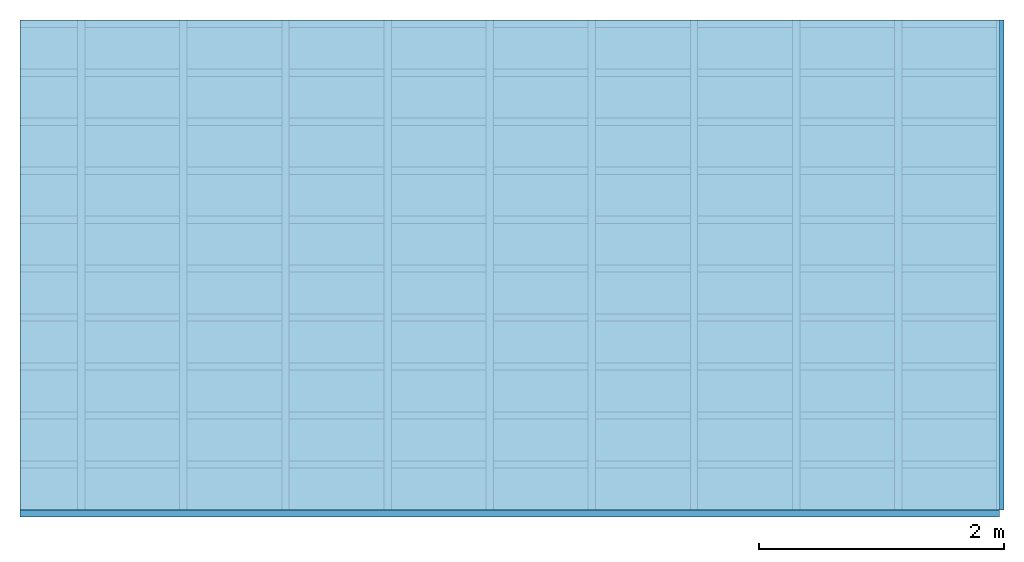
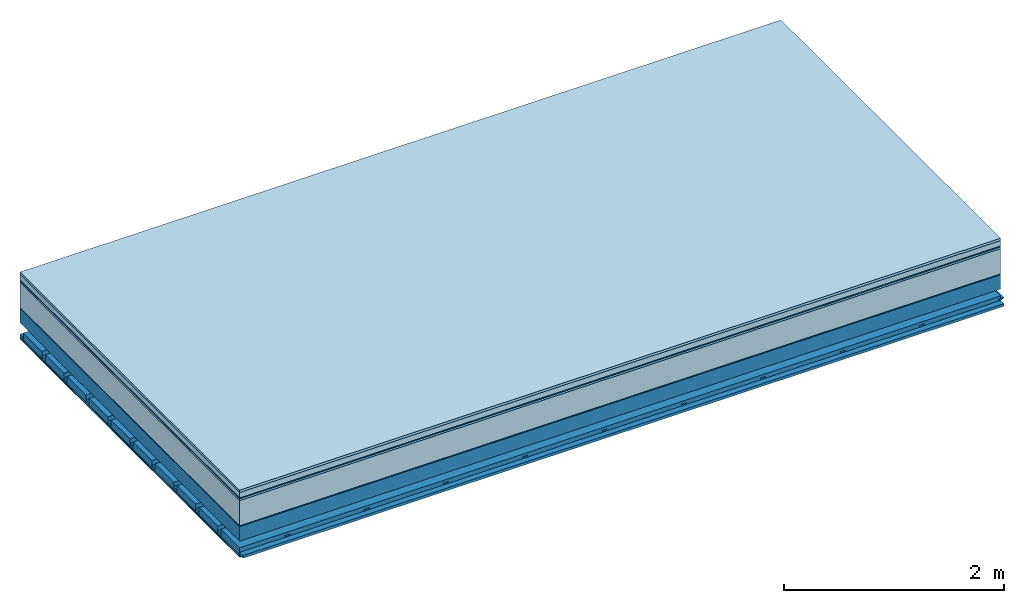
# One storey: 9 plates, 4 members, 1 element without a shape of its own.
"""IFC4 building model written with IfcOpenShell, lengths in metres."""

from ifc_helpers import new_model, si_unit, derived_unit, direction, frame, frame_2d, origin, origin_with_axes, place, context, project, spatial, polyline, rectangle, outline, extrude, material, layer, layer_set, type_object, element, aggregate, save


model = new_model("IFC4")

# Units and contexts
plan_context = context("Plan", 3, precision=1e-05, world=origin(), true_north=direction((0.0, 1.0)))
model_context = context("Model", 3, precision=1e-05, world=origin(), true_north=direction((0.0, 1.0)))
ifc_project = project(units=[si_unit("LENGTHUNIT", "METRE"), derived_unit("SOUNDPRESSUREUNIT", [(si_unit("PRESSUREUNIT", "PASCAL", prefix="MICRO"), 0)]), si_unit("ENERGYUNIT", "JOULE", prefix="MEGA"), si_unit("MASSUNIT", "GRAM", prefix="KILO"), derived_unit("THERMALTRANSMITTANCEUNIT", [(si_unit("POWERUNIT", "WATT"), 1), (si_unit("AREAUNIT", "SQUARE_METRE"), -1), (si_unit("THERMODYNAMICTEMPERATUREUNIT", "KELVIN"), -1)]), derived_unit("AREADENSITYUNIT", [(si_unit("MASSUNIT", "GRAM", prefix="KILO"), 1), (si_unit("AREAUNIT", "SQUARE_METRE"), -1)]), derived_unit("USERDEFINED", [(si_unit("ENERGYUNIT", "JOULE", prefix="MEGA"), 1), (si_unit("AREAUNIT", "SQUARE_METRE"), -1)])], contexts=[plan_context, model_context])

# Site, building, storey
site = spatial("IfcSite", under=ifc_project)
building_placement = place(None, origin())
building = spatial("IfcBuilding", under=site, at=building_placement)
storey_placement = place(building_placement, origin())
storey = spatial("IfcBuildingStorey", under=building, at=storey_placement)

# Slab, members, plates
ifc_material_1 = material(Category="07.009")
ifc_layer_1 = layer(ifc_material_1, 0.026, Name="Use and protection layer 3")
ifc_material_2 = material(Category="07.011")
ifc_layer_2 = layer(ifc_material_2, 0.06, Name="Use and protection layer 2")
ifc_material_3 = material(Name="Protective layer + Fire protection cover RF1", Category="09.007")
ifc_layer_3 = layer(ifc_material_3, 0.01, Name="Use and protection layer 1")
ifc_material_4 = material(Name="Bituminous", Category="09.003")
ifc_layer_4 = layer(ifc_material_4, 0.02, Name="Seal")
ifc_material_5 = material(Name="Mineral wool", Category="10.008")
ifc_layer_5 = layer(ifc_material_5, 0.28, Name="Exterior insulation layer 1")
ifc_material_6 = material(Name="Vapor-permeable barrier", Category="09.006")
ifc_layer_6 = layer(ifc_material_6, 0.01, Name="layer / temporary roof")
ifc_material_7 = material(Name="no composite action")
ifc_layer_7 = layer(ifc_material_7, 0.0, Name="Bond")
ifc_layer_8 = layer(None, 0.16, Name="Support")
ifc_layer_9 = layer(ifc_material_7, 0.0, Name="Bond")
ifc_layer_10 = layer(None, 0.125, Name="Coupling")
ifc_layer_11 = layer(None, 0.03, Name="Battens / profiles")
ifc_material_8 = material(Name="Plasterboard type A", Category="03.008")
ifc_layer_12 = layer(ifc_material_8, 0.0125, Name="Covering below 1st layer")
ifc_layer_13 = layer(ifc_material_8, 0.0125, Name="Covering below 2nd layer")
ifc_material_9 = material(Category="04.001")
ifc_layer_14 = layer(ifc_material_9, 0.003, Name="Surface below")
ifc_layer_set = layer_set([ifc_layer_1, ifc_layer_2, ifc_layer_3, ifc_layer_4, ifc_layer_5, ifc_layer_6, ifc_layer_7, ifc_layer_8, ifc_layer_9, ifc_layer_10, ifc_layer_11, ifc_layer_12, ifc_layer_13, ifc_layer_14])
slab_type = type_object("IfcSlabType", Name="F0071", PredefinedType="NOTDEFINED", material=ifc_layer_set)
slab_placement = place(None, frame((0.0, 0.0, 0.0), z_axis=(0.0, 0.0, -1.0), x_axis=(1.0, 0.0, 0.0)))
slab = element("IfcSlab", 1, at=slab_placement, inside=storey, type_object=slab_type, material=ifc_layer_set, Name="Slab #1")
ifc_material_10 = material(Name="Solid timber panel")
member_1_placement = place(slab_placement, origin())
member_1 = element("IfcMember", 2, at=member_1_placement, material=ifc_material_10, Name="Support", context=plan_context, shape_type="SweptSolid", body=[
    extrude(rectangle(XDim=1.0, YDim=0.16, at=frame_2d((0.5, 0.08), x_axis=(1.0, 0.0))), frame((0.0, 4.0, 0.406), z_axis=(0.0, -1.0, 0.0), x_axis=(1.0, 0.0, 0.0)), (0.0, 0.0, 1.0), 4.0),
    extrude(rectangle(XDim=1.0, YDim=0.16, at=frame_2d((0.5, 0.08), x_axis=(1.0, 0.0))), frame((1.0, 4.0, 0.406), z_axis=(0.0, -1.0, 0.0), x_axis=(1.0, 0.0, 0.0)), (0.0, 0.0, 1.0), 4.0),
    extrude(rectangle(XDim=1.0, YDim=0.16, at=frame_2d((0.5, 0.08), x_axis=(1.0, 0.0))), frame((2.0, 4.0, 0.406), z_axis=(0.0, -1.0, 0.0), x_axis=(1.0, 0.0, 0.0)), (0.0, 0.0, 1.0), 4.0),
    extrude(rectangle(XDim=1.0, YDim=0.16, at=frame_2d((0.5, 0.08), x_axis=(1.0, 0.0))), frame((3.0, 4.0, 0.406), z_axis=(0.0, -1.0, 0.0), x_axis=(1.0, 0.0, 0.0)), (0.0, 0.0, 1.0), 4.0),
    extrude(rectangle(XDim=1.0, YDim=0.16, at=frame_2d((0.5, 0.08), x_axis=(1.0, 0.0))), frame((4.0, 4.0, 0.406), z_axis=(0.0, -1.0, 0.0), x_axis=(1.0, 0.0, 0.0)), (0.0, 0.0, 1.0), 4.0),
    extrude(rectangle(XDim=1.0, YDim=0.16, at=frame_2d((0.5, 0.08), x_axis=(1.0, 0.0))), frame((5.0, 4.0, 0.406), z_axis=(0.0, -1.0, 0.0), x_axis=(1.0, 0.0, 0.0)), (0.0, 0.0, 1.0), 4.0),
    extrude(rectangle(XDim=1.0, YDim=0.16, at=frame_2d((0.5, 0.08), x_axis=(1.0, 0.0))), frame((6.0, 4.0, 0.406), z_axis=(0.0, -1.0, 0.0), x_axis=(1.0, 0.0, 0.0)), (0.0, 0.0, 1.0), 4.0),
    extrude(rectangle(XDim=1.0, YDim=0.16, at=frame_2d((0.5, 0.08), x_axis=(1.0, 0.0))), frame((7.0, 4.0, 0.406), z_axis=(0.0, -1.0, 0.0), x_axis=(1.0, 0.0, 0.0)), (0.0, 0.0, 1.0), 4.0),
])
ifc_material_11 = material()
member_2_placement = place(slab_placement, origin())
member_2 = element("IfcMember", 3, at=member_2_placement, material=ifc_material_11, Name="Coupling", context=plan_context, shape_type="SweptSolid", body=[
    extrude(outline(polyline([(0.0, 0.0), (0.06, 0.0), (0.04, 0.02), (0.02, 0.02), (0.0, 0.0)])), frame((0.47, 4.0, 0.671), z_axis=(0.0, -1.0, 0.0), x_axis=(1.0, 0.0, 0.0)), (0.0, 0.0, 1.0), 4.0),
    extrude(outline(polyline([(0.0, 0.0), (0.06, 0.0), (0.04, 0.02), (0.02, 0.02), (0.0, 0.0)])), frame((1.304, 4.0, 0.671), z_axis=(0.0, -1.0, 0.0), x_axis=(1.0, 0.0, 0.0)), (0.0, 0.0, 1.0), 4.0),
    extrude(outline(polyline([(0.0, 0.0), (0.06, 0.0), (0.04, 0.02), (0.02, 0.02), (0.0, 0.0)])), frame((2.138, 4.0, 0.671), z_axis=(0.0, -1.0, 0.0), x_axis=(1.0, 0.0, 0.0)), (0.0, 0.0, 1.0), 4.0),
    extrude(outline(polyline([(0.0, 0.0), (0.06, 0.0), (0.04, 0.02), (0.02, 0.02), (0.0, 0.0)])), frame((2.972, 4.0, 0.671), z_axis=(0.0, -1.0, 0.0), x_axis=(1.0, 0.0, 0.0)), (0.0, 0.0, 1.0), 4.0),
    extrude(outline(polyline([(0.0, 0.0), (0.06, 0.0), (0.04, 0.02), (0.02, 0.02), (0.0, 0.0)])), frame((3.806, 4.0, 0.671), z_axis=(0.0, -1.0, 0.0), x_axis=(1.0, 0.0, 0.0)), (0.0, 0.0, 1.0), 4.0),
    extrude(outline(polyline([(0.0, 0.0), (0.06, 0.0), (0.04, 0.02), (0.02, 0.02), (0.0, 0.0)])), frame((4.64, 4.0, 0.671), z_axis=(0.0, -1.0, 0.0), x_axis=(1.0, 0.0, 0.0)), (0.0, 0.0, 1.0), 4.0),
    extrude(outline(polyline([(0.0, 0.0), (0.06, 0.0), (0.04, 0.02), (0.02, 0.02), (0.0, 0.0)])), frame((5.474, 4.0, 0.671), z_axis=(0.0, -1.0, 0.0), x_axis=(1.0, 0.0, 0.0)), (0.0, 0.0, 1.0), 4.0),
    extrude(outline(polyline([(0.0, 0.0), (0.06, 0.0), (0.04, 0.02), (0.02, 0.02), (0.0, 0.0)])), frame((6.308, 4.0, 0.671), z_axis=(0.0, -1.0, 0.0), x_axis=(1.0, 0.0, 0.0)), (0.0, 0.0, 1.0), 4.0),
    extrude(outline(polyline([(0.0, 0.0), (0.06, 0.0), (0.04, 0.02), (0.02, 0.02), (0.0, 0.0)])), frame((7.142, 4.0, 0.671), z_axis=(0.0, -1.0, 0.0), x_axis=(1.0, 0.0, 0.0)), (0.0, 0.0, 1.0), 4.0),
    extrude(outline(polyline([(0.0, 0.0), (0.06, 0.0), (0.04, 0.02), (0.02, 0.02), (0.0, 0.0)])), frame((7.976, 4.0, 0.671), z_axis=(0.0, -1.0, 0.0), x_axis=(1.0, 0.0, 0.0)), (0.0, 0.0, 1.0), 4.0),
])
member_3_placement = place(slab_placement, origin())
member_3 = element("IfcMember", 4, at=member_3_placement, material=ifc_material_11, Name="Battens / profiles", context=plan_context, shape_type="SweptSolid", body=[
    extrude(rectangle(XDim=0.06, YDim=0.03, at=frame_2d((0.03, 0.015), x_axis=(1.0, 0.0))), frame((0.0, 0.0, 0.691), z_axis=(1.0, 0.0, 0.0), x_axis=(0.0, 1.0, 0.0)), (0.0, 0.0, 1.0), 8.0),
    extrude(rectangle(XDim=0.06, YDim=0.03, at=frame_2d((0.03, 0.015), x_axis=(1.0, 0.0))), frame((0.0, 0.4, 0.691), z_axis=(1.0, 0.0, 0.0), x_axis=(0.0, 1.0, 0.0)), (0.0, 0.0, 1.0), 8.0),
    extrude(rectangle(XDim=0.06, YDim=0.03, at=frame_2d((0.03, 0.015), x_axis=(1.0, 0.0))), frame((0.0, 0.8, 0.691), z_axis=(1.0, 0.0, 0.0), x_axis=(0.0, 1.0, 0.0)), (0.0, 0.0, 1.0), 8.0),
    extrude(rectangle(XDim=0.06, YDim=0.03, at=frame_2d((0.03, 0.015), x_axis=(1.0, 0.0))), frame((0.0, 1.2, 0.691), z_axis=(1.0, 0.0, 0.0), x_axis=(0.0, 1.0, 0.0)), (0.0, 0.0, 1.0), 8.0),
    extrude(rectangle(XDim=0.06, YDim=0.03, at=frame_2d((0.03, 0.015), x_axis=(1.0, 0.0))), frame((0.0, 1.6, 0.691), z_axis=(1.0, 0.0, 0.0), x_axis=(0.0, 1.0, 0.0)), (0.0, 0.0, 1.0), 8.0),
    extrude(rectangle(XDim=0.06, YDim=0.03, at=frame_2d((0.03, 0.015), x_axis=(1.0, 0.0))), frame((0.0, 2.0, 0.691), z_axis=(1.0, 0.0, 0.0), x_axis=(0.0, 1.0, 0.0)), (0.0, 0.0, 1.0), 8.0),
    extrude(rectangle(XDim=0.06, YDim=0.03, at=frame_2d((0.03, 0.015), x_axis=(1.0, 0.0))), frame((0.0, 2.4, 0.691), z_axis=(1.0, 0.0, 0.0), x_axis=(0.0, 1.0, 0.0)), (0.0, 0.0, 1.0), 8.0),
    extrude(rectangle(XDim=0.06, YDim=0.03, at=frame_2d((0.03, 0.015), x_axis=(1.0, 0.0))), frame((0.0, 2.8, 0.691), z_axis=(1.0, 0.0, 0.0), x_axis=(0.0, 1.0, 0.0)), (0.0, 0.0, 1.0), 8.0),
    extrude(rectangle(XDim=0.06, YDim=0.03, at=frame_2d((0.03, 0.015), x_axis=(1.0, 0.0))), frame((0.0, 3.2, 0.691), z_axis=(1.0, 0.0, 0.0), x_axis=(0.0, 1.0, 0.0)), (0.0, 0.0, 1.0), 8.0),
    extrude(rectangle(XDim=0.06, YDim=0.03, at=frame_2d((0.03, 0.015), x_axis=(1.0, 0.0))), frame((0.0, 3.6, 0.691), z_axis=(1.0, 0.0, 0.0), x_axis=(0.0, 1.0, 0.0)), (0.0, 0.0, 1.0), 8.0),
    extrude(rectangle(XDim=0.06, YDim=0.03, at=frame_2d((0.03, 0.015), x_axis=(1.0, 0.0))), frame((0.0, 4.0, 0.691), z_axis=(1.0, 0.0, 0.0), x_axis=(0.0, 1.0, 0.0)), (0.0, 0.0, 1.0), 8.0),
])
ifc_material_12 = material()
member_4_placement = place(slab_placement, origin())
member_4 = element("IfcMember", 5, at=member_4_placement, material=ifc_material_12, Name="Cavity", context=plan_context, shape_type="SweptSolid", body=[
    extrude(rectangle(XDim=0.34, YDim=0.08, at=frame_2d((0.17, 0.04), x_axis=(1.0, 0.0))), frame((0.0, 0.06, 0.641), z_axis=(1.0, 0.0, 0.0), x_axis=(0.0, 1.0, 0.0)), (0.0, 0.0, 1.0), 8.0),
    extrude(rectangle(XDim=0.34, YDim=0.08, at=frame_2d((0.17, 0.04), x_axis=(1.0, 0.0))), frame((0.0, 0.46, 0.641), z_axis=(1.0, 0.0, 0.0), x_axis=(0.0, 1.0, 0.0)), (0.0, 0.0, 1.0), 8.0),
    extrude(rectangle(XDim=0.34, YDim=0.08, at=frame_2d((0.17, 0.04), x_axis=(1.0, 0.0))), frame((0.0, 0.86, 0.641), z_axis=(1.0, 0.0, 0.0), x_axis=(0.0, 1.0, 0.0)), (0.0, 0.0, 1.0), 8.0),
    extrude(rectangle(XDim=0.34, YDim=0.08, at=frame_2d((0.17, 0.04), x_axis=(1.0, 0.0))), frame((0.0, 1.26, 0.641), z_axis=(1.0, 0.0, 0.0), x_axis=(0.0, 1.0, 0.0)), (0.0, 0.0, 1.0), 8.0),
    extrude(rectangle(XDim=0.34, YDim=0.08, at=frame_2d((0.17, 0.04), x_axis=(1.0, 0.0))), frame((0.0, 1.66, 0.641), z_axis=(1.0, 0.0, 0.0), x_axis=(0.0, 1.0, 0.0)), (0.0, 0.0, 1.0), 8.0),
    extrude(rectangle(XDim=0.34, YDim=0.08, at=frame_2d((0.17, 0.04), x_axis=(1.0, 0.0))), frame((0.0, 2.06, 0.641), z_axis=(1.0, 0.0, 0.0), x_axis=(0.0, 1.0, 0.0)), (0.0, 0.0, 1.0), 8.0),
    extrude(rectangle(XDim=0.34, YDim=0.08, at=frame_2d((0.17, 0.04), x_axis=(1.0, 0.0))), frame((0.0, 2.46, 0.641), z_axis=(1.0, 0.0, 0.0), x_axis=(0.0, 1.0, 0.0)), (0.0, 0.0, 1.0), 8.0),
    extrude(rectangle(XDim=0.34, YDim=0.08, at=frame_2d((0.17, 0.04), x_axis=(1.0, 0.0))), frame((0.0, 2.86, 0.641), z_axis=(1.0, 0.0, 0.0), x_axis=(0.0, 1.0, 0.0)), (0.0, 0.0, 1.0), 8.0),
    extrude(rectangle(XDim=0.34, YDim=0.08, at=frame_2d((0.17, 0.04), x_axis=(1.0, 0.0))), frame((0.0, 3.26, 0.641), z_axis=(1.0, 0.0, 0.0), x_axis=(0.0, 1.0, 0.0)), (0.0, 0.0, 1.0), 8.0),
    extrude(rectangle(XDim=0.34, YDim=0.08, at=frame_2d((0.17, 0.04), x_axis=(1.0, 0.0))), frame((0.0, 3.66, 0.641), z_axis=(1.0, 0.0, 0.0), x_axis=(0.0, 1.0, 0.0)), (0.0, 0.0, 1.0), 8.0),
])
plate_1_placement = place(slab_placement, origin())
plate_1 = element("IfcPlate", 6, at=plate_1_placement, material=ifc_material_1, Name="Use and protection layer 3", context=plan_context, shape_type="SweptSolid", body=[
    extrude(rectangle(XDim=8.0, YDim=4.0, at=frame_2d((4.0, 2.0), x_axis=(1.0, 0.0))), origin_with_axes(), (0.0, 0.0, 1.0), 0.026),
])
plate_2_placement = place(slab_placement, origin())
plate_2 = element("IfcPlate", 7, at=plate_2_placement, material=ifc_material_2, Name="Use and protection layer 2", context=plan_context, shape_type="SweptSolid", body=[
    extrude(rectangle(XDim=8.0, YDim=4.0, at=frame_2d((4.0, 2.0), x_axis=(1.0, 0.0))), frame((0.0, 0.0, 0.026), z_axis=(0.0, 0.0, 1.0), x_axis=(1.0, 0.0, 0.0)), (0.0, 0.0, 1.0), 0.06),
])
plate_3_placement = place(slab_placement, origin())
plate_3 = element("IfcPlate", 8, at=plate_3_placement, material=ifc_material_3, Name="Use and protection layer 1", context=plan_context, shape_type="SweptSolid", body=[
    extrude(rectangle(XDim=8.0, YDim=4.0, at=frame_2d((4.0, 2.0), x_axis=(1.0, 0.0))), frame((0.0, 0.0, 0.086), z_axis=(0.0, 0.0, 1.0), x_axis=(1.0, 0.0, 0.0)), (0.0, 0.0, 1.0), 0.01),
])
plate_4_placement = place(slab_placement, origin())
plate_4 = element("IfcPlate", 9, at=plate_4_placement, material=ifc_material_4, Name="Seal", context=plan_context, shape_type="SweptSolid", body=[
    extrude(rectangle(XDim=8.0, YDim=4.0, at=frame_2d((4.0, 2.0), x_axis=(1.0, 0.0))), frame((0.0, 0.0, 0.096), z_axis=(0.0, 0.0, 1.0), x_axis=(1.0, 0.0, 0.0)), (0.0, 0.0, 1.0), 0.02),
])
plate_5_placement = place(slab_placement, origin())
plate_5 = element("IfcPlate", 10, at=plate_5_placement, material=ifc_material_5, Name="Exterior insulation layer 1", context=plan_context, shape_type="SweptSolid", body=[
    extrude(rectangle(XDim=8.0, YDim=4.0, at=frame_2d((4.0, 2.0), x_axis=(1.0, 0.0))), frame((0.0, 0.0, 0.116), z_axis=(0.0, 0.0, 1.0), x_axis=(1.0, 0.0, 0.0)), (0.0, 0.0, 1.0), 0.28),
])
plate_6_placement = place(slab_placement, origin())
plate_6 = element("IfcPlate", 11, at=plate_6_placement, material=ifc_material_6, Name="layer / temporary roof", context=plan_context, shape_type="SweptSolid", body=[
    extrude(rectangle(XDim=8.0, YDim=4.0, at=frame_2d((4.0, 2.0), x_axis=(1.0, 0.0))), frame((0.0, 0.0, 0.396), z_axis=(0.0, 0.0, 1.0), x_axis=(1.0, 0.0, 0.0)), (0.0, 0.0, 1.0), 0.01),
])
plate_7_placement = place(slab_placement, origin())
plate_7 = element("IfcPlate", 12, at=plate_7_placement, material=ifc_material_8, Name="Covering below 1st layer", context=plan_context, shape_type="SweptSolid", body=[
    extrude(rectangle(XDim=8.0, YDim=4.0, at=frame_2d((4.0, 2.0), x_axis=(1.0, 0.0))), frame((0.0, 0.0, 0.721), z_axis=(0.0, 0.0, 1.0), x_axis=(1.0, 0.0, 0.0)), (0.0, 0.0, 1.0), 0.0125),
])
plate_8_placement = place(slab_placement, origin())
plate_8 = element("IfcPlate", 13, at=plate_8_placement, material=ifc_material_8, Name="Covering below 2nd layer", context=plan_context, shape_type="SweptSolid", body=[
    extrude(rectangle(XDim=8.0, YDim=4.0, at=frame_2d((4.0, 2.0), x_axis=(1.0, 0.0))), frame((0.0, 0.0, 0.7335), z_axis=(0.0, 0.0, 1.0), x_axis=(1.0, 0.0, 0.0)), (0.0, 0.0, 1.0), 0.0125),
])
plate_9_placement = place(slab_placement, origin())
plate_9 = element("IfcPlate", 14, at=plate_9_placement, material=ifc_material_9, Name="Surface below", context=plan_context, shape_type="SweptSolid", body=[
    extrude(rectangle(XDim=8.0, YDim=4.0, at=frame_2d((4.0, 2.0), x_axis=(1.0, 0.0))), frame((0.0, 0.0, 0.746), z_axis=(0.0, 0.0, 1.0), x_axis=(1.0, 0.0, 0.0)), (0.0, 0.0, 1.0), 0.003),
])
aggregate(slab, [plate_1, plate_2, plate_3, plate_4, plate_5, plate_6, member_1, member_2, member_3, member_4, plate_7, plate_8, plate_9])

save(model, "model.ifc")
